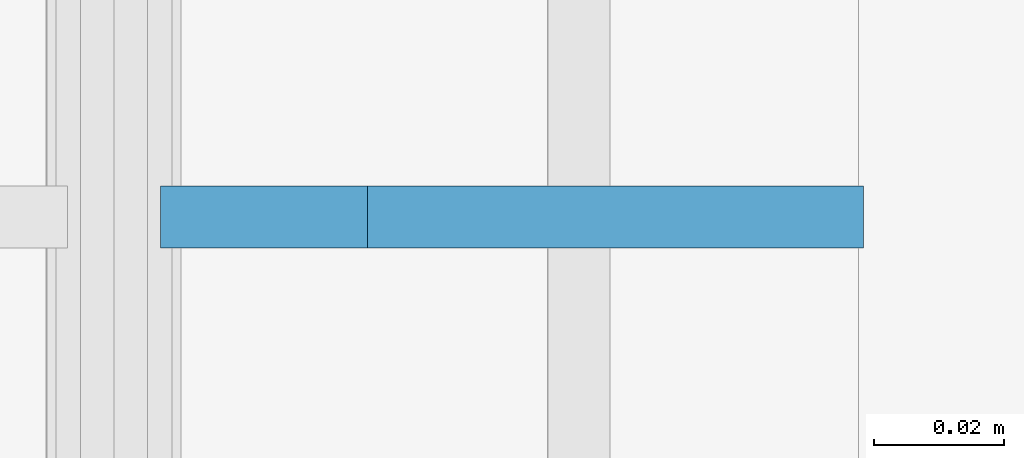
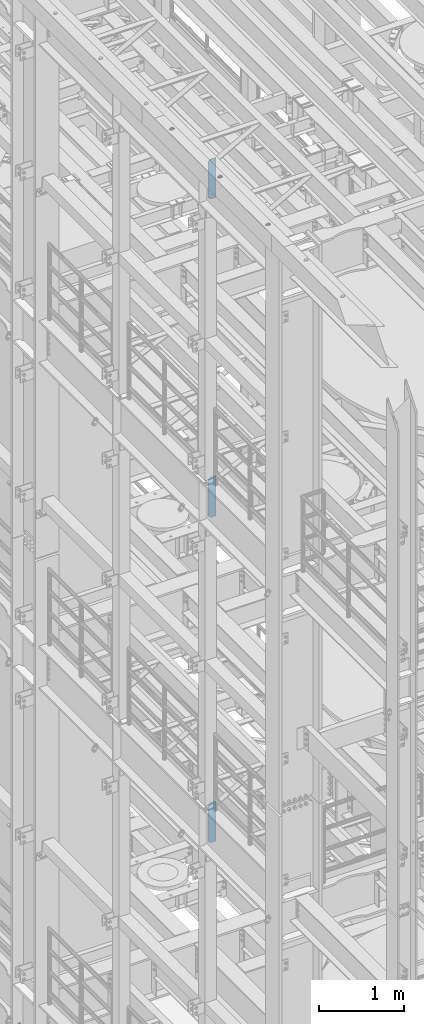
# One storey, part 1482 of 1876: 3 plates, 3 elements without a shape of their own.
"""IFC2X3 building model written with IfcOpenShell, lengths in millimetres."""

from ifc_helpers import new_model, si_unit, frame, origin_with_axes, place, context, subcontext, project, spatial, faceted_brep, material, type_object, element, aggregate, save


model = new_model("IFC2X3")

# Units and contexts
model_context = context("Model", 3, precision=1e-05, world=origin_with_axes())
body_context = subcontext(model_context, "Body", "Model", "MODEL_VIEW")
ifc_project = project(units=[si_unit("LENGTHUNIT", "METRE", prefix="MILLI"), si_unit("AREAUNIT", "SQUARE_METRE"), si_unit("VOLUMEUNIT", "CUBIC_METRE"), si_unit("MASSUNIT", "GRAM", prefix="KILO"), si_unit("TIMEUNIT", "SECOND"), si_unit("PLANEANGLEUNIT", "RADIAN"), si_unit("SOLIDANGLEUNIT", "STERADIAN"), si_unit("THERMODYNAMICTEMPERATUREUNIT", "DEGREE_CELSIUS"), si_unit("LUMINOUSINTENSITYUNIT", "LUMEN")], contexts=[model_context])

# Site, building, storey
site_placement = place(None, origin_with_axes())
site = spatial("IfcSite", under=ifc_project, at=site_placement, CompositionType="ELEMENT")
building_placement = place(site_placement, origin_with_axes())
building = spatial("IfcBuilding", under=site, at=building_placement, Name="Undefined", CompositionType="ELEMENT")
storey_placement = place(building_placement, origin_with_axes())
storey = spatial("IfcBuildingStorey", under=building, at=storey_placement, Name="Undefined", CompositionType="ELEMENT", Elevation=0.0)

# Assembly, plate
assembly_1_placement = place(storey_placement, origin_with_axes())
assembly_1 = element("IfcElementAssembly", 1, at=assembly_1_placement, inside=storey, Name="BEAM", AssemblyPlace="NOTDEFINED", PredefinedType="RIGID_FRAME")
ifc_material = material(Name="STEEL/A36")
plate_type = type_object("IfcPlateType", PredefinedType="NOTDEFINED")
plate_1_placement = place(assembly_1_placement, frame((115.093746948242, -2539.9999995053, 21958.3), z_axis=(0.0, 0.0, 1.0), x_axis=(-1.0, 0.0, 0.0)))
plate_1 = element("IfcPlate", 2, at=plate_1_placement, type_object=plate_type, material=ifc_material, Name="PLATE", context=body_context, shape_type="Brep", body=[
    faceted_brep([(0.0, -4.76249999999982, 0.0), (0.0, -4.76249999999982, 571.5), (0.0, 4.76249999999982, 571.5), (0.0, 4.76249999999982, 0.0), (76.1999969482422, -4.76249999999982, 571.5), (76.1999969482422, 4.76249999999982, 571.5), (107.949996948242, -4.76249999999982, 539.75), (107.949996948242, 4.76249999999982, 539.75), (107.949996948242, -4.76249999999982, 31.75), (107.949996948242, 4.76249999999982, 31.75), (76.1999969482422, -4.76250000000073, 0.0), (76.1999969482422, 4.76250000000073, 0.0)], [[[0, 1, 2, 3]], [[1, 4, 5, 2]], [[4, 6, 7, 5]], [[6, 8, 9, 7]], [[8, 10, 11, 9]], [[10, 0, 3, 11]], [[5, 7, 9, 11, 3, 2]], [[10, 8, 6, 4, 1, 0]]]),
])
aggregate(assembly_1, [plate_1])

assembly_2_placement = place(storey_placement, origin_with_axes())
assembly_2 = element("IfcElementAssembly", 3, at=assembly_2_placement, inside=storey, Name="BEAM", AssemblyPlace="NOTDEFINED", PredefinedType="RIGID_FRAME")
plate_2_placement = place(assembly_2_placement, frame((115.093782056805, -2539.99999974382, 17386.3), z_axis=(0.0, 0.0, 1.0), x_axis=(-1.0, 0.0, 0.0)))
plate_2 = element("IfcPlate", 4, at=plate_2_placement, type_object=plate_type, material=ifc_material, Name="PLATE", context=body_context, shape_type="Brep", body=[
    faceted_brep([(0.0, -4.76249999999982, 0.0), (0.0, -4.76249999999982, 571.5), (0.0, 4.76249999999982, 571.5), (0.0, 4.76249999999982, 0.0), (76.1999969482422, -4.76249999999982, 571.5), (76.1999969482422, 4.76249999999982, 571.5), (107.949996948242, -4.76249999999982, 539.75), (107.949996948242, 4.76249999999982, 539.75), (107.949996948242, -4.76249999999982, 31.75), (107.949996948242, 4.76249999999982, 31.75), (76.1999969482422, -4.76250000000073, 0.0), (76.1999969482422, 4.76250000000073, 0.0)], [[[0, 1, 2, 3]], [[1, 4, 5, 2]], [[4, 6, 7, 5]], [[6, 8, 9, 7]], [[8, 10, 11, 9]], [[10, 0, 3, 11]], [[5, 7, 9, 11, 3, 2]], [[10, 8, 6, 4, 1, 0]]]),
])
aggregate(assembly_2, [plate_2])

assembly_3_placement = place(storey_placement, origin_with_axes())
assembly_3 = element("IfcElementAssembly", 5, at=assembly_3_placement, inside=storey, Name="BEAM", AssemblyPlace="NOTDEFINED", PredefinedType="RIGID_FRAME")
plate_3_placement = place(assembly_3_placement, frame((115.093754918769, -2539.99999974382, 12712.7), z_axis=(0.0, 0.0, 1.0), x_axis=(-1.0, 0.0, 0.0)))
plate_3 = element("IfcPlate", 6, at=plate_3_placement, type_object=plate_type, material=ifc_material, Name="PLATE", context=body_context, shape_type="Brep", body=[
    faceted_brep([(0.0, -4.76249999999982, 0.0), (0.0, -4.76249999999982, 571.5), (0.0, 4.76249999999982, 571.5), (0.0, 4.76249999999982, 0.0), (76.1999969482422, -4.76249999999982, 571.5), (76.1999969482422, 4.76249999999982, 571.5), (107.949996948242, -4.76249999999982, 539.75), (107.949996948242, 4.76249999999982, 539.75), (107.949996948242, -4.76249999999982, 31.75), (107.949996948242, 4.76249999999982, 31.75), (76.1999969482422, -4.76250000000073, 0.0), (76.1999969482422, 4.76250000000073, 0.0)], [[[0, 1, 2, 3]], [[1, 4, 5, 2]], [[4, 6, 7, 5]], [[6, 8, 9, 7]], [[8, 10, 11, 9]], [[10, 0, 3, 11]], [[5, 7, 9, 11, 3, 2]], [[10, 8, 6, 4, 1, 0]]]),
])
aggregate(assembly_3, [plate_3])

save(model, "model.ifc")
